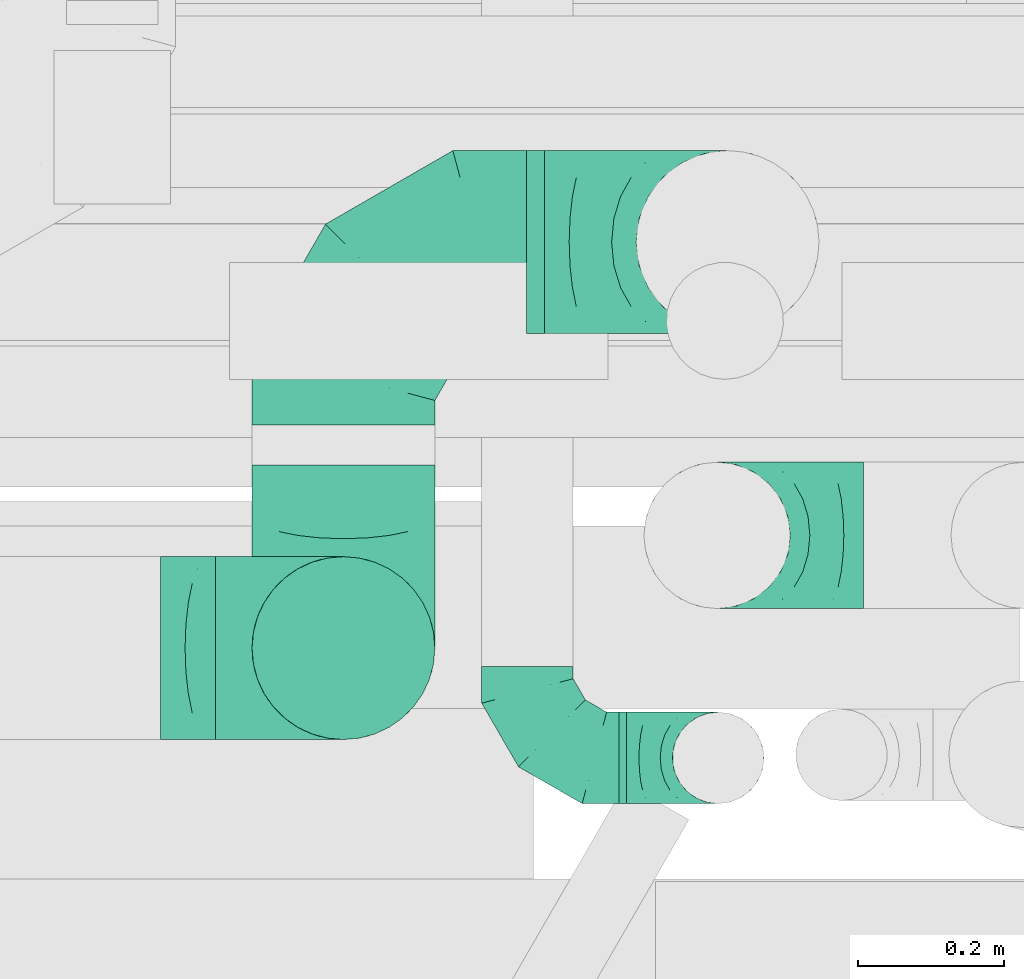
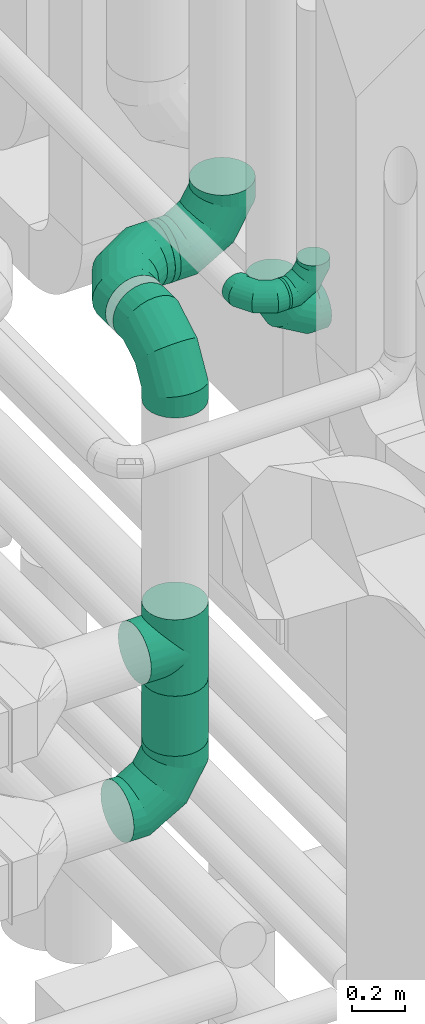
# One storey, part 299 of 337: 8 flow fittings, 3 flow segments.
"""IFC2X3 building model written with IfcOpenShell, lengths in millimetres."""

from ifc_helpers import new_model, entity, si_unit, converted_unit, derived_unit, direction, frame, origin, origin_2d_with_axis, place, context, subcontext, project, spatial, circle, extrude, faceted_brep, source, transform, mapped, material, type_object, type_shapes, element, save


model = new_model("IFC2X3")

# Units and contexts
model_context = context("Model", 3, precision=0.01, world=origin(), true_north=direction((6.12303176911189e-17, 1.0)))
body_context = subcontext(model_context, "Body", "Model", "MODEL_VIEW")
ifc_project = project(units=[si_unit("LENGTHUNIT", "METRE", prefix="MILLI"), si_unit("AREAUNIT", "SQUARE_METRE"), si_unit("VOLUMEUNIT", "CUBIC_METRE"), converted_unit("PLANEANGLEUNIT", "DEGREE", entity("IfcRatioMeasure", 0.0174532925199433), si_unit("PLANEANGLEUNIT", "RADIAN"), dimensions=[0, 0, 0, 0, 0, 0, 0]), si_unit("MASSUNIT", "GRAM", prefix="KILO"), derived_unit("MASSDENSITYUNIT", [(si_unit("MASSUNIT", "GRAM", prefix="KILO"), 1), (si_unit("LENGTHUNIT", "METRE"), -3)]), derived_unit("MOMENTOFINERTIAUNIT", [(si_unit("LENGTHUNIT", "METRE"), 4)]), si_unit("TIMEUNIT", "SECOND"), si_unit("FREQUENCYUNIT", "HERTZ"), si_unit("THERMODYNAMICTEMPERATUREUNIT", "DEGREE_CELSIUS"), derived_unit("THERMALTRANSMITTANCEUNIT", [(si_unit("MASSUNIT", "GRAM", prefix="KILO"), 1), (si_unit("THERMODYNAMICTEMPERATUREUNIT", "KELVIN"), -1), (si_unit("TIMEUNIT", "SECOND"), -3)]), derived_unit("VOLUMETRICFLOWRATEUNIT", [(si_unit("LENGTHUNIT", "METRE"), 3), (si_unit("TIMEUNIT", "SECOND"), -1)]), derived_unit("MASSFLOWRATEUNIT", [(si_unit("MASSUNIT", "GRAM", prefix="KILO"), 1), (si_unit("TIMEUNIT", "SECOND"), -1)]), derived_unit("ROTATIONALFREQUENCYUNIT", [(si_unit("TIMEUNIT", "SECOND"), -1)]), si_unit("ELECTRICCURRENTUNIT", "AMPERE"), si_unit("ELECTRICVOLTAGEUNIT", "VOLT"), si_unit("POWERUNIT", "WATT"), si_unit("FORCEUNIT", "NEWTON", prefix="KILO"), si_unit("ILLUMINANCEUNIT", "LUX"), si_unit("LUMINOUSFLUXUNIT", "LUMEN"), si_unit("LUMINOUSINTENSITYUNIT", "CANDELA"), derived_unit("USERDEFINED", [(si_unit("MASSUNIT", "GRAM", prefix="KILO"), -1), (si_unit("LENGTHUNIT", "METRE"), -2), (si_unit("TIMEUNIT", "SECOND"), 3), (si_unit("LUMINOUSFLUXUNIT", "LUMEN"), 1)]), derived_unit("LINEARVELOCITYUNIT", [(si_unit("LENGTHUNIT", "METRE"), 1), (si_unit("TIMEUNIT", "SECOND"), -1)]), si_unit("PRESSUREUNIT", "PASCAL"), derived_unit("USERDEFINED", [(si_unit("LENGTHUNIT", "METRE"), -2), (si_unit("MASSUNIT", "GRAM", prefix="KILO"), 1), (si_unit("TIMEUNIT", "SECOND"), -2)]), derived_unit("LINEARFORCEUNIT", [(si_unit("MASSUNIT", "GRAM", prefix="KILO"), 1), (si_unit("LENGTHUNIT", "METRE"), 1), (si_unit("TIMEUNIT", "SECOND"), -2), (si_unit("LENGTHUNIT", "METRE"), -1)]), derived_unit("PLANARFORCEUNIT", [(si_unit("MASSUNIT", "GRAM", prefix="KILO"), 1), (si_unit("LENGTHUNIT", "METRE"), 1), (si_unit("TIMEUNIT", "SECOND"), -2), (si_unit("LENGTHUNIT", "METRE"), -2)])], contexts=[model_context])

# Site, building, storey
site_placement = place(None, origin())
site = spatial("IfcSite", under=ifc_project, at=site_placement, CompositionType="ELEMENT")
building_placement = place(site_placement, origin())
building = spatial("IfcBuilding", under=site, at=building_placement, CompositionType="ELEMENT")
storey_placement = place(building_placement, origin())
storey = spatial("IfcBuildingStorey", under=building, at=storey_placement, CompositionType="ELEMENT", Elevation=0.0)

# Flow segments
duct_segment_type = type_object("IfcDuctSegmentType", PredefinedType="NOTDEFINED")
flow_segment_1_placement = place(storey_placement, frame((70743.1, 9622.1, 35423.4)))
element("IfcFlowSegment", 1, at=flow_segment_1_placement, inside=storey, type_object=duct_segment_type, context=body_context, shape_type="SweptSolid", body=[
    extrude(circle(Radius=125.0, at=origin_2d_with_axis()), frame((0.0, 126.6, 126.6), z_axis=(1.0, 0.0, 0.0), x_axis=(0.0, -1.0, 0.0)), (0.0, 0.0, 1.0), 24.9999999999164),
])
flow_segment_2_placement = place(storey_placement, frame((70869.58, 8979.52, 35675.9)))
element("IfcFlowSegment", 2, at=flow_segment_2_placement, inside=storey, type_object=duct_segment_type, context=body_context, shape_type="SweptSolid", body=[
    extrude(circle(Radius=62.5, at=origin_2d_with_axis()), frame((0.0, 64.1, 64.1), z_axis=(1.0, 0.0, 0.0), x_axis=(0.0, -1.0, 0.0)), (0.0, 0.0, 1.0), 10.6752096480788),
])
flow_segment_3_placement = place(storey_placement, frame((70366.5, 9067.1, 33750.0)))
element("IfcFlowSegment", 3, at=flow_segment_3_placement, inside=storey, type_object=duct_segment_type, context=body_context, shape_type="SweptSolid", body=[
    extrude(circle(Radius=125.0, at=origin_2d_with_axis()), frame((126.6, 126.6, 0.0), z_axis=(0.0, 0.0, 1.0), x_axis=(0.0, 1.0, 0.0)), (0.0, 0.0, 1.0), 275.000000000007),
])

# Flow fittings
ifc_material = material()
duct_fitting_type_1 = type_object("IfcDuctFittingType", PredefinedType="NOTDEFINED", material=ifc_material)
shared_shape_1 = source(origin(), body_context, "Body", "Brep", [
    faceted_brep([(-250.0, 0.0, -125.0), (-250.0, -32.35, -120.74), (-250.0, -62.5, -108.25), (-250.0, -88.39, -88.39), (-250.0, -108.25, -62.5), (-250.0, -120.74, -32.35), (-250.0, -125.0, 0.0), (-250.0, -120.74, 32.35), (-250.0, -108.25, 62.5), (-250.0, -88.39, 88.39), (-250.0, -62.5, 108.25), (-250.0, -32.35, 120.74), (-250.0, 0.0, 125.0), (-250.0, 32.35, 120.74), (-250.0, 62.5, 108.25), (-250.0, 88.39, 88.39), (-250.0, 108.25, 62.5), (-250.0, 120.74, 32.35), (-250.0, 125.0, 0.0), (-250.0, 120.74, -32.35), (-250.0, 108.25, -62.5), (-250.0, 88.39, -88.39), (-250.0, 62.5, -108.25), (-250.0, 32.35, -120.74), (-191.68, 32.35, 120.74), (-199.76, 62.5, 108.25), (-183.01, 0.0, 125.0), (-206.7, 88.39, 88.39), (-215.37, 120.74, 32.35), (-216.51, 125.0, 0.0), (-212.02, 108.25, 62.5), (-212.02, 108.25, -62.5), (-206.7, 88.39, -88.39), (-215.37, 120.74, -32.35), (-191.68, 32.35, -120.74), (-183.01, 0.0, -125.0), (-199.76, 62.5, -108.25), (-174.34, -32.35, -120.74), (-166.27, -62.5, -108.25), (-159.33, -88.39, -88.39), (-154.01, -108.25, -62.5), (-150.66, -120.74, -32.35), (-149.52, -125.0, 0.0), (-150.66, -120.74, 32.35), (-154.01, -108.25, 62.5), (-159.33, -88.39, 88.39), (-166.27, -62.5, 108.25), (-174.34, -32.35, 120.74), (-90.67, 90.67, 120.74), (-112.74, 112.74, 108.25), (-66.99, 66.99, 125.0), (-131.69, 131.69, 88.39), (-146.23, 146.23, 62.5), (-155.38, 155.38, 32.35), (-158.49, 158.49, 0.0), (-155.38, 155.38, -32.35), (-146.23, 146.23, -62.5), (-131.69, 131.69, -88.39), (-90.67, 90.67, -120.74), (-66.99, 66.99, -125.0), (-112.74, 112.74, -108.25), (-43.3, 43.3, -120.74), (-21.23, 21.23, -108.25), (-2.28, 2.28, -88.39), (12.26, -12.26, -62.5), (21.4, -21.4, -32.35), (24.52, -24.52, 0.0), (21.4, -21.4, 32.35), (12.26, -12.26, 62.5), (-2.28, 2.28, 88.39), (-21.23, 21.23, 108.25), (-43.3, 43.3, 120.74), (-32.35, 191.68, 120.74), (-62.5, 199.76, 108.25), (0.0, 183.01, 125.0), (-88.39, 206.7, 88.39), (-108.25, 212.02, 62.5), (-120.74, 215.37, 32.35), (-125.0, 216.51, 0.0), (-120.74, 215.37, -32.35), (-108.25, 212.02, -62.5), (-88.39, 206.7, -88.39), (-32.35, 191.68, -120.74), (0.0, 183.01, -125.0), (-62.5, 199.76, -108.25), (32.35, 174.34, -120.74), (62.5, 166.27, -108.25), (88.39, 159.33, -88.39), (108.25, 154.01, -62.5), (120.74, 150.66, -32.35), (125.0, 149.52, 0.0), (120.74, 150.66, 32.35), (108.25, 154.01, 62.5), (88.39, 159.33, 88.39), (62.5, 166.27, 108.25), (32.35, 174.34, 120.74), (-32.35, 250.0, -120.74), (-62.5, 250.0, -108.25), (-88.39, 250.0, -88.39), (-108.25, 250.0, -62.5), (-120.74, 250.0, -32.35), (-125.0, 250.0, 0.0), (-120.74, 250.0, 32.35), (-108.25, 250.0, 62.5), (-88.39, 250.0, 88.39), (-62.5, 250.0, 108.25), (-32.35, 250.0, 120.74), (0.0, 250.0, 125.0), (32.35, 250.0, 120.74), (62.5, 250.0, 108.25), (88.39, 250.0, 88.39), (108.25, 250.0, 62.5), (120.74, 250.0, 32.35), (125.0, 250.0, 0.0), (120.74, 250.0, -32.35), (108.25, 250.0, -62.5), (88.39, 250.0, -88.39), (62.5, 250.0, -108.25), (32.35, 250.0, -120.74), (0.0, 250.0, -125.0)], [[[0, 1, 2, 3, 4, 5, 6, 7, 8, 9, 10, 11, 12, 13, 14, 15, 16, 17, 18, 19, 20, 21, 22, 23]], [[24, 25, 14, 13]], [[26, 24, 13, 12]], [[14, 25, 27, 15]], [[28, 29, 18, 17]], [[30, 28, 17, 16]], [[15, 27, 30, 16]], [[20, 31, 32, 21]], [[33, 31, 20, 19]], [[18, 29, 33, 19]], [[34, 35, 0, 23]], [[36, 34, 23, 22]], [[21, 32, 36, 22]], [[1, 0, 35, 37]], [[2, 1, 37, 38]], [[38, 39, 3, 2]], [[5, 4, 40, 41]], [[6, 5, 41, 42]], [[39, 40, 4, 3]], [[6, 42, 43, 7]], [[7, 43, 44, 8]], [[8, 44, 45, 9]], [[9, 45, 46, 10]], [[10, 46, 47, 11]], [[26, 12, 11, 47]], [[48, 49, 25, 24]], [[50, 48, 24, 26]], [[27, 25, 49, 51]], [[52, 53, 28, 30]], [[51, 52, 30, 27]], [[29, 28, 53, 54]], [[55, 56, 31, 33]], [[54, 55, 33, 29]], [[32, 31, 56, 57]], [[58, 59, 35, 34]], [[60, 58, 34, 36]], [[57, 60, 36, 32]], [[37, 35, 59, 61]], [[38, 37, 61, 62]], [[39, 38, 62, 63]], [[41, 40, 64, 65]], [[42, 41, 65, 66]], [[63, 64, 40, 39]], [[43, 42, 66, 67]], [[44, 43, 67, 68]], [[68, 69, 45, 44]], [[46, 45, 69, 70]], [[47, 46, 70, 71]], [[26, 47, 71, 50]], [[72, 73, 49, 48]], [[74, 72, 48, 50]], [[51, 49, 73, 75]], [[76, 77, 53, 52]], [[75, 76, 52, 51]], [[54, 53, 77, 78]], [[79, 80, 56, 55]], [[78, 79, 55, 54]], [[57, 56, 80, 81]], [[82, 83, 59, 58]], [[84, 82, 58, 60]], [[81, 84, 60, 57]], [[61, 59, 83, 85]], [[62, 61, 85, 86]], [[63, 62, 86, 87]], [[65, 64, 88, 89]], [[66, 65, 89, 90]], [[87, 88, 64, 63]], [[67, 66, 90, 91]], [[68, 67, 91, 92]], [[92, 93, 69, 68]], [[70, 69, 93, 94]], [[71, 70, 94, 95]], [[50, 71, 95, 74]], [[96, 97, 98, 99, 100, 101, 102, 103, 104, 105, 106, 107, 108, 109, 110, 111, 112, 113, 114, 115, 116, 117, 118, 119]], [[72, 74, 107, 106]], [[73, 72, 106, 105]], [[75, 73, 105, 104]], [[77, 76, 103, 102]], [[78, 77, 102, 101]], [[75, 104, 103, 76]], [[78, 101, 100, 79]], [[79, 100, 99, 80]], [[80, 99, 98, 81]], [[84, 97, 96, 82]], [[82, 96, 119, 83]], [[84, 81, 98, 97]], [[83, 119, 118, 85]], [[85, 118, 117, 86]], [[116, 87, 86, 117]], [[88, 115, 114, 89]], [[89, 114, 113, 90]], [[115, 88, 87, 116]], [[91, 90, 113, 112]], [[92, 91, 112, 111]], [[111, 110, 93, 92]], [[95, 94, 109, 108]], [[74, 95, 108, 107]], [[110, 109, 94, 93]]]),
])
type_shapes(duct_fitting_type_1, [shared_shape_1])
for number, where, z_axis, x_axis in (
    (4, (70493.1, 9193.7, 35550.0), (-1.0, 0.0, 0.0), (0.0, 0.0, 1.0)),
    (5, (70493.1, 9748.7, 35550.0), (0.0, 0.0, 1.0), (-1.0, 0.0, 0.0)),
    (6, (71018.1, 9748.7, 35550.0), (0.0, -1.0, 0.0), (1.0, 0.0, 0.0)),
    (7, (70493.1, 9193.7, 33500.0), (0.0, -1.0, 0.0), (1.0, 0.0, 0.0)),
):
    element("IfcFlowFitting", number, at=place(storey_placement, frame(where, z_axis=z_axis, x_axis=x_axis)), inside=storey, type_object=duct_fitting_type_1, material=ifc_material, context=body_context, shape_type="MappedRepresentation", body=[
        mapped(shared_shape_1, transform((0.0, 0.0, 0.0), scale=1.0)),
    ])
duct_fitting_type_2 = type_object("IfcDuctFittingType", PredefinedType="NOTDEFINED", material=ifc_material)
shared_shape_2 = source(origin(), body_context, "Body", "Brep", [
    faceted_brep([(-200.0, 0.0, -100.0), (-200.0, -25.88, -96.59), (-200.0, -50.0, -86.6), (-200.0, -70.71, -70.71), (-200.0, -86.6, -50.0), (-200.0, -96.59, -25.88), (-200.0, -100.0, 0.0), (-200.0, -96.59, 25.88), (-200.0, -86.6, 50.0), (-200.0, -70.71, 70.71), (-200.0, -50.0, 86.6), (-200.0, -25.88, 96.59), (-200.0, 0.0, 100.0), (-200.0, 25.88, 96.59), (-200.0, 50.0, 86.6), (-200.0, 70.71, 70.71), (-200.0, 86.6, 50.0), (-200.0, 96.59, 25.88), (-200.0, 100.0, 0.0), (-200.0, 96.59, -25.88), (-200.0, 86.6, -50.0), (-200.0, 70.71, -70.71), (-200.0, 50.0, -86.6), (-200.0, 25.88, -96.59), (-153.35, 25.88, 96.59), (-159.81, 50.0, 86.6), (-146.41, 0.0, 100.0), (-165.36, 70.71, 70.71), (-172.29, 96.59, 25.88), (-173.21, 100.0, 0.0), (-169.62, 86.6, 50.0), (-169.62, 86.6, -50.0), (-165.36, 70.71, -70.71), (-172.29, 96.59, -25.88), (-153.35, 25.88, -96.59), (-146.41, 0.0, -100.0), (-159.81, 50.0, -86.6), (-139.48, -25.88, -96.59), (-133.01, -50.0, -86.6), (-127.46, -70.71, -70.71), (-123.21, -86.6, -50.0), (-120.53, -96.59, -25.88), (-119.62, -100.0, 0.0), (-120.53, -96.59, 25.88), (-123.21, -86.6, 50.0), (-127.46, -70.71, 70.71), (-133.01, -50.0, 86.6), (-139.48, -25.88, 96.59), (-72.54, 72.54, 96.59), (-90.19, 90.19, 86.6), (-53.59, 53.59, 100.0), (-105.35, 105.35, 70.71), (-116.99, 116.99, 50.0), (-124.3, 124.3, 25.88), (-126.79, 126.79, 0.0), (-124.3, 124.3, -25.88), (-116.99, 116.99, -50.0), (-105.35, 105.35, -70.71), (-72.54, 72.54, -96.59), (-53.59, 53.59, -100.0), (-90.19, 90.19, -86.6), (-34.64, 34.64, -96.59), (-16.99, 16.99, -86.6), (-1.83, 1.83, -70.71), (9.81, -9.81, -50.0), (17.12, -17.12, -25.88), (19.62, -19.62, 0.0), (17.12, -17.12, 25.88), (9.81, -9.81, 50.0), (-1.83, 1.83, 70.71), (-16.99, 16.99, 86.6), (-34.64, 34.64, 96.59), (-25.88, 153.35, 96.59), (-50.0, 159.81, 86.6), (0.0, 146.41, 100.0), (-70.71, 165.36, 70.71), (-86.6, 169.62, 50.0), (-96.59, 172.29, 25.88), (-100.0, 173.21, 0.0), (-96.59, 172.29, -25.88), (-86.6, 169.62, -50.0), (-70.71, 165.36, -70.71), (-25.88, 153.35, -96.59), (0.0, 146.41, -100.0), (-50.0, 159.81, -86.6), (25.88, 139.48, -96.59), (50.0, 133.01, -86.6), (70.71, 127.46, -70.71), (86.6, 123.21, -50.0), (96.59, 120.53, -25.88), (100.0, 119.62, 0.0), (96.59, 120.53, 25.88), (86.6, 123.21, 50.0), (70.71, 127.46, 70.71), (50.0, 133.01, 86.6), (25.88, 139.48, 96.59), (-25.88, 200.0, -96.59), (-50.0, 200.0, -86.6), (-70.71, 200.0, -70.71), (-86.6, 200.0, -50.0), (-96.59, 200.0, -25.88), (-100.0, 200.0, 0.0), (-96.59, 200.0, 25.88), (-86.6, 200.0, 50.0), (-70.71, 200.0, 70.71), (-50.0, 200.0, 86.6), (-25.88, 200.0, 96.59), (0.0, 200.0, 100.0), (25.88, 200.0, 96.59), (50.0, 200.0, 86.6), (70.71, 200.0, 70.71), (86.6, 200.0, 50.0), (96.59, 200.0, 25.88), (100.0, 200.0, 0.0), (96.59, 200.0, -25.88), (86.6, 200.0, -50.0), (70.71, 200.0, -70.71), (50.0, 200.0, -86.6), (25.88, 200.0, -96.59), (0.0, 200.0, -100.0)], [[[0, 1, 2, 3, 4, 5, 6, 7, 8, 9, 10, 11, 12, 13, 14, 15, 16, 17, 18, 19, 20, 21, 22, 23]], [[24, 25, 14, 13]], [[26, 24, 13, 12]], [[14, 25, 27, 15]], [[28, 29, 18, 17]], [[30, 28, 17, 16]], [[15, 27, 30, 16]], [[20, 31, 32, 21]], [[33, 31, 20, 19]], [[18, 29, 33, 19]], [[34, 35, 0, 23]], [[36, 34, 23, 22]], [[32, 36, 22, 21]], [[1, 0, 35, 37]], [[2, 1, 37, 38]], [[38, 39, 3, 2]], [[5, 4, 40, 41]], [[6, 5, 41, 42]], [[39, 40, 4, 3]], [[6, 42, 43, 7]], [[7, 43, 44, 8]], [[8, 44, 45, 9]], [[9, 45, 46, 10]], [[10, 46, 47, 11]], [[26, 12, 11, 47]], [[48, 49, 25, 24]], [[50, 48, 24, 26]], [[27, 25, 49, 51]], [[52, 53, 28, 30]], [[51, 52, 30, 27]], [[29, 28, 53, 54]], [[55, 56, 31, 33]], [[54, 55, 33, 29]], [[32, 31, 56, 57]], [[58, 59, 35, 34]], [[60, 58, 34, 36]], [[57, 60, 36, 32]], [[37, 35, 59, 61]], [[38, 37, 61, 62]], [[39, 38, 62, 63]], [[41, 40, 64, 65]], [[42, 41, 65, 66]], [[63, 64, 40, 39]], [[43, 42, 66, 67]], [[44, 43, 67, 68]], [[68, 69, 45, 44]], [[46, 45, 69, 70]], [[47, 46, 70, 71]], [[26, 47, 71, 50]], [[72, 73, 49, 48]], [[74, 72, 48, 50]], [[51, 49, 73, 75]], [[76, 77, 53, 52]], [[75, 76, 52, 51]], [[54, 53, 77, 78]], [[79, 80, 56, 55]], [[78, 79, 55, 54]], [[57, 56, 80, 81]], [[82, 83, 59, 58]], [[84, 82, 58, 60]], [[81, 84, 60, 57]], [[61, 59, 83, 85]], [[62, 61, 85, 86]], [[63, 62, 86, 87]], [[65, 64, 88, 89]], [[66, 65, 89, 90]], [[87, 88, 64, 63]], [[67, 66, 90, 91]], [[68, 67, 91, 92]], [[92, 93, 69, 68]], [[70, 69, 93, 94]], [[71, 70, 94, 95]], [[50, 71, 95, 74]], [[96, 97, 98, 99, 100, 101, 102, 103, 104, 105, 106, 107, 108, 109, 110, 111, 112, 113, 114, 115, 116, 117, 118, 119]], [[72, 74, 107, 106]], [[73, 72, 106, 105]], [[75, 73, 105, 104]], [[102, 101, 78, 77]], [[103, 102, 77, 76]], [[75, 104, 103, 76]], [[78, 101, 100, 79]], [[79, 100, 99, 80]], [[80, 99, 98, 81]], [[84, 97, 96, 82]], [[82, 96, 119, 83]], [[84, 81, 98, 97]], [[118, 117, 86, 85]], [[119, 118, 85, 83]], [[116, 87, 86, 117]], [[88, 115, 114, 89]], [[89, 114, 113, 90]], [[115, 88, 87, 116]], [[91, 90, 113, 112]], [[92, 91, 112, 111]], [[111, 110, 93, 92]], [[95, 94, 109, 108]], [[74, 95, 108, 107]], [[110, 109, 94, 93]]]),
])
type_shapes(duct_fitting_type_2, [shared_shape_2])
flow_fitting_1_placement = place(storey_placement, frame((71003.8, 9347.75, 35400.0), z_axis=(0.0, 1.0, 0.0), x_axis=(-1.0, 0.0, 0.0)))
element("IfcFlowFitting", 8, at=flow_fitting_1_placement, inside=storey, type_object=duct_fitting_type_2, material=ifc_material, context=body_context, shape_type="MappedRepresentation", body=[
    mapped(shared_shape_2, transform((0.0, 0.0, 0.0), scale=1.0)),
])
duct_fitting_type_3 = type_object("IfcDuctFittingType", PredefinedType="NOTDEFINED", material=ifc_material)
shared_shape_3 = source(origin(), body_context, "Body", "Brep", [
    faceted_brep([(-125.0, 0.0, -62.5), (-125.0, -16.18, -60.37), (-125.0, -31.25, -54.13), (-125.0, -44.19, -44.19), (-125.0, -54.13, -31.25), (-125.0, -60.37, -16.18), (-125.0, -62.5, 0.0), (-125.0, -60.37, 16.18), (-125.0, -54.13, 31.25), (-125.0, -44.19, 44.19), (-125.0, -31.25, 54.13), (-125.0, -16.18, 60.37), (-125.0, 0.0, 62.5), (-125.0, 16.18, 60.37), (-125.0, 31.25, 54.13), (-125.0, 44.19, 44.19), (-125.0, 54.13, 31.25), (-125.0, 60.37, 16.18), (-125.0, 62.5, 0.0), (-125.0, 60.37, -16.18), (-125.0, 54.13, -31.25), (-125.0, 44.19, -44.19), (-125.0, 31.25, -54.13), (-125.0, 16.18, -60.37), (-95.84, 16.18, 60.37), (-99.88, 31.25, 54.13), (-91.51, 0.0, 62.5), (-103.35, 44.19, 44.19), (-107.68, 60.37, 16.18), (-108.25, 62.5, 0.0), (-106.01, 54.13, 31.25), (-106.01, 54.13, -31.25), (-103.35, 44.19, -44.19), (-107.68, 60.37, -16.18), (-95.84, 16.18, -60.37), (-91.51, 0.0, -62.5), (-99.88, 31.25, -54.13), (-87.17, -16.18, -60.37), (-83.13, -31.25, -54.13), (-79.66, -44.19, -44.19), (-77.0, -54.13, -31.25), (-75.33, -60.37, -16.18), (-74.76, -62.5, 0.0), (-75.33, -60.37, 16.18), (-77.0, -54.13, 31.25), (-79.66, -44.19, 44.19), (-83.13, -31.25, 54.13), (-87.17, -16.18, 60.37), (-45.34, 45.34, 60.37), (-56.37, 56.37, 54.13), (-33.49, 33.49, 62.5), (-65.85, 65.85, 44.19), (-73.12, 73.12, 31.25), (-77.69, 77.69, 16.18), (-79.25, 79.25, 0.0), (-77.69, 77.69, -16.18), (-73.12, 73.12, -31.25), (-65.85, 65.85, -44.19), (-45.34, 45.34, -60.37), (-33.49, 33.49, -62.5), (-56.37, 56.37, -54.13), (-21.65, 21.65, -60.37), (-10.62, 10.62, -54.13), (-1.14, 1.14, -44.19), (6.13, -6.13, -31.25), (10.7, -10.7, -16.18), (12.26, -12.26, 0.0), (10.7, -10.7, 16.18), (6.13, -6.13, 31.25), (-1.14, 1.14, 44.19), (-10.62, 10.62, 54.13), (-21.65, 21.65, 60.37), (-16.18, 95.84, 60.37), (-31.25, 99.88, 54.13), (0.0, 91.51, 62.5), (-44.19, 103.35, 44.19), (-54.13, 106.01, 31.25), (-60.37, 107.68, 16.18), (-62.5, 108.25, 0.0), (-60.37, 107.68, -16.18), (-54.13, 106.01, -31.25), (-44.19, 103.35, -44.19), (-16.18, 95.84, -60.37), (0.0, 91.51, -62.5), (-31.25, 99.88, -54.13), (16.18, 87.17, -60.37), (31.25, 83.13, -54.13), (44.19, 79.66, -44.19), (54.13, 77.0, -31.25), (60.37, 75.33, -16.18), (62.5, 74.76, 0.0), (60.37, 75.33, 16.18), (54.13, 77.0, 31.25), (44.19, 79.66, 44.19), (31.25, 83.13, 54.13), (16.18, 87.17, 60.37), (-16.18, 125.0, -60.37), (-31.25, 125.0, -54.13), (-44.19, 125.0, -44.19), (-54.13, 125.0, -31.25), (-60.37, 125.0, -16.18), (-62.5, 125.0, 0.0), (-60.37, 125.0, 16.18), (-54.13, 125.0, 31.25), (-44.19, 125.0, 44.19), (-31.25, 125.0, 54.13), (-16.18, 125.0, 60.37), (0.0, 125.0, 62.5), (16.18, 125.0, 60.37), (31.25, 125.0, 54.13), (44.19, 125.0, 44.19), (54.13, 125.0, 31.25), (60.37, 125.0, 16.18), (62.5, 125.0, 0.0), (60.37, 125.0, -16.18), (54.13, 125.0, -31.25), (44.19, 125.0, -44.19), (31.25, 125.0, -54.13), (16.18, 125.0, -60.37), (0.0, 125.0, -62.5)], [[[0, 1, 2, 3, 4, 5, 6, 7, 8, 9, 10, 11, 12, 13, 14, 15, 16, 17, 18, 19, 20, 21, 22, 23]], [[24, 25, 14, 13]], [[26, 24, 13, 12]], [[14, 25, 27, 15]], [[28, 29, 18, 17]], [[30, 28, 17, 16]], [[15, 27, 30, 16]], [[20, 31, 32, 21]], [[33, 31, 20, 19]], [[18, 29, 33, 19]], [[34, 35, 0, 23]], [[36, 34, 23, 22]], [[21, 32, 36, 22]], [[1, 0, 35, 37]], [[2, 1, 37, 38]], [[38, 39, 3, 2]], [[5, 4, 40, 41]], [[6, 5, 41, 42]], [[39, 40, 4, 3]], [[6, 42, 43, 7]], [[7, 43, 44, 8]], [[45, 9, 8, 44]], [[9, 45, 46, 10]], [[10, 46, 47, 11]], [[26, 12, 11, 47]], [[48, 49, 25, 24]], [[50, 48, 24, 26]], [[27, 25, 49, 51]], [[52, 53, 28, 30]], [[51, 52, 30, 27]], [[29, 28, 53, 54]], [[55, 56, 31, 33]], [[54, 55, 33, 29]], [[57, 32, 31, 56]], [[58, 59, 35, 34]], [[60, 58, 34, 36]], [[57, 60, 36, 32]], [[37, 35, 59, 61]], [[38, 37, 61, 62]], [[39, 38, 62, 63]], [[41, 40, 64, 65]], [[42, 41, 65, 66]], [[63, 64, 40, 39]], [[43, 42, 66, 67]], [[44, 43, 67, 68]], [[68, 69, 45, 44]], [[46, 45, 69, 70]], [[47, 46, 70, 71]], [[26, 47, 71, 50]], [[72, 73, 49, 48]], [[74, 72, 48, 50]], [[51, 49, 73, 75]], [[76, 77, 53, 52]], [[75, 76, 52, 51]], [[54, 53, 77, 78]], [[79, 80, 56, 55]], [[78, 79, 55, 54]], [[81, 57, 56, 80]], [[82, 83, 59, 58]], [[84, 82, 58, 60]], [[81, 84, 60, 57]], [[61, 59, 83, 85]], [[62, 61, 85, 86]], [[63, 62, 86, 87]], [[65, 64, 88, 89]], [[66, 65, 89, 90]], [[87, 88, 64, 63]], [[67, 66, 90, 91]], [[68, 67, 91, 92]], [[92, 93, 69, 68]], [[70, 69, 93, 94]], [[71, 70, 94, 95]], [[50, 71, 95, 74]], [[96, 97, 98, 99, 100, 101, 102, 103, 104, 105, 106, 107, 108, 109, 110, 111, 112, 113, 114, 115, 116, 117, 118, 119]], [[72, 74, 107, 106]], [[73, 72, 106, 105]], [[75, 73, 105, 104]], [[77, 76, 103, 102]], [[78, 77, 102, 101]], [[75, 104, 103, 76]], [[78, 101, 100, 79]], [[79, 100, 99, 80]], [[80, 99, 98, 81]], [[96, 119, 83, 82]], [[97, 96, 82, 84]], [[84, 81, 98, 97]], [[83, 119, 118, 85]], [[85, 118, 117, 86]], [[116, 87, 86, 117]], [[88, 115, 114, 89]], [[89, 114, 113, 90]], [[115, 88, 87, 116]], [[91, 90, 113, 112]], [[92, 91, 112, 111]], [[111, 110, 93, 92]], [[95, 94, 109, 108]], [[74, 95, 108, 107]], [[110, 109, 94, 93]]]),
])
type_shapes(duct_fitting_type_3, [shared_shape_3])
for number, where, z_axis, x_axis in (
    (9, (70744.58, 9043.62, 35740.0), (0.0, 0.0, 1.0), (0.0, -1.0, 0.0)),
    (10, (71005.26, 9043.62, 35740.0), (0.0, -1.0, 0.0), (1.0, 0.0, 0.0)),
):
    element("IfcFlowFitting", number, at=place(storey_placement, frame(where, z_axis=z_axis, x_axis=x_axis)), inside=storey, type_object=duct_fitting_type_3, material=ifc_material, context=body_context, shape_type="MappedRepresentation", body=[
        mapped(shared_shape_3, transform((0.0, 0.0, 0.0), scale=1.0)),
    ])
duct_fitting_type_4 = type_object("IfcDuctFittingType", PredefinedType="NOTDEFINED", material=ifc_material)
shared_shape_4 = source(origin(), body_context, "Body", "Brep", [
    faceted_brep([(22.44, -22.44, -122.97), (175.0, 0.0, -125.0), (175.0, -32.35, -120.74), (175.0, -62.5, -108.25), (75.83, -75.83, -99.37), (65.72, -65.72, -106.33), (175.0, -88.39, -88.39), (55.24, -55.24, -112.13), (11.24, -11.24, -124.49), (0.0, 0.0, -125.0), (-11.24, -11.24, -124.49), (-175.0, 0.0, -125.0), (44.49, -44.49, -116.81), (33.54, -33.54, -120.42), (175.0, -108.25, -62.5), (102.86, -102.86, -71.03), (175.0, -120.74, -32.35), (116.36, -116.36, -45.66), (175.0, -114.5, -47.43), (123.99, -123.99, -15.84), (175.0, -125.0, 0.0), (125.0, -125.0, 0.0), (-123.99, -123.99, -15.84), (-125.0, -125.0, 0.0), (-175.0, -125.0, 0.0), (175.0, -122.87, -16.18), (110.21, -110.21, -58.98), (121.05, -121.05, -31.19), (94.55, -94.55, -81.76), (85.49, -85.49, -91.2), (123.99, -123.99, 15.84), (-123.99, -123.99, 15.84), (175.0, -114.5, 47.43), (175.0, -108.25, 62.5), (110.21, -110.21, 58.98), (175.0, -120.74, 32.35), (121.05, -121.05, 31.19), (175.0, -122.87, 16.18), (102.86, -102.86, 71.03), (175.0, -88.39, 88.39), (116.36, -116.36, 45.66), (94.55, -94.55, 81.76), (85.49, -85.49, 91.2), (75.83, -75.83, 99.37), (65.72, -65.72, 106.33), (175.0, -62.5, 108.25), (55.24, -55.24, 112.13), (175.0, -32.35, 120.74), (22.44, -22.44, 122.97), (175.0, 0.0, 125.0), (44.49, -44.49, 116.81), (33.54, -33.54, 120.42), (11.24, -11.24, 124.49), (0.0, 0.0, 125.0), (-11.24, -11.24, 124.49), (-175.0, 0.0, 125.0), (32.35, -175.0, -120.74), (62.5, -175.0, -108.25), (88.39, -175.0, -88.39), (108.25, -175.0, -62.5), (114.5, -175.0, -47.43), (120.74, -175.0, -32.35), (122.87, -175.0, -16.18), (125.0, -175.0, 0.0), (122.87, -175.0, 16.18), (120.74, -175.0, 32.35), (114.5, -175.0, 47.43), (108.25, -175.0, 62.5), (88.39, -175.0, 88.39), (62.5, -175.0, 108.25), (32.35, -175.0, 120.74), (0.0, -175.0, 125.0), (-32.35, -175.0, 120.74), (-62.5, -175.0, 108.25), (-88.39, -175.0, 88.39), (-108.25, -175.0, 62.5), (-114.5, -175.0, 47.43), (-120.74, -175.0, 32.35), (-122.87, -175.0, 16.18), (-125.0, -175.0, 0.0), (-122.87, -175.0, -16.18), (-120.74, -175.0, -32.35), (-114.5, -175.0, -47.43), (-108.25, -175.0, -62.5), (-88.39, -175.0, -88.39), (-62.5, -175.0, -108.25), (-32.35, -175.0, -120.74), (0.0, -175.0, -125.0), (-22.44, -22.44, -122.97), (-75.83, -75.83, -99.37), (-65.72, -65.72, -106.33), (-55.24, -55.24, -112.13), (-44.49, -44.49, -116.81), (-33.54, -33.54, -120.42), (-102.86, -102.86, -71.03), (-116.36, -116.36, -45.66), (-110.21, -110.21, -58.98), (-121.05, -121.05, -31.19), (-94.55, -94.55, -81.76), (-85.49, -85.49, -91.2), (-110.21, -110.21, 58.98), (-121.05, -121.05, 31.19), (-102.86, -102.86, 71.03), (-116.36, -116.36, 45.66), (-94.55, -94.55, 81.76), (-85.49, -85.49, 91.2), (-75.83, -75.83, 99.37), (-65.72, -65.72, 106.33), (-55.24, -55.24, 112.13), (-22.44, -22.44, 122.97), (-44.49, -44.49, 116.81), (-33.54, -33.54, 120.42), (-175.0, -32.35, -120.74), (-175.0, -62.5, -108.25), (-175.0, -88.39, -88.39), (-175.0, -108.25, -62.5), (-175.0, -114.5, -47.43), (-175.0, -120.74, -32.35), (-175.0, -122.87, -16.18), (-175.0, -122.87, 16.18), (-175.0, -120.74, 32.35), (-175.0, -114.5, 47.43), (-175.0, -108.25, 62.5), (-175.0, -88.39, 88.39), (-175.0, -62.5, 108.25), (-175.0, -32.35, 120.74), (-175.0, 32.35, 120.74), (-175.0, 62.5, 108.25), (-175.0, 88.39, 88.39), (-175.0, 108.25, 62.5), (-175.0, 120.74, 32.35), (-175.0, 125.0, 0.0), (-175.0, 120.74, -32.35), (-175.0, 108.25, -62.5), (-175.0, 88.39, -88.39), (-175.0, 62.5, -108.25), (-175.0, 32.35, -120.74), (175.0, 32.35, -120.74), (175.0, 62.5, -108.25), (175.0, 88.39, -88.39), (175.0, 108.25, -62.5), (175.0, 120.74, -32.35), (175.0, 125.0, 0.0), (175.0, 120.74, 32.35), (175.0, 108.25, 62.5), (175.0, 88.39, 88.39), (175.0, 62.5, 108.25), (175.0, 32.35, 120.74)], [[[0, 1, 2]], [[3, 4, 5]], [[4, 3, 6]], [[2, 3, 7]], [[5, 7, 3]], [[8, 9, 1]], [[9, 10, 11]], [[0, 8, 1]], [[12, 13, 2]], [[7, 12, 2]], [[0, 2, 13]], [[14, 15, 6]], [[16, 17, 18]], [[19, 20, 21]], [[22, 23, 24]], [[20, 19, 25]], [[26, 18, 17]], [[27, 16, 25]], [[28, 29, 6]], [[15, 28, 6]], [[27, 25, 19]], [[26, 14, 18]], [[27, 17, 16]], [[15, 14, 26]], [[6, 29, 4]], [[30, 21, 20]], [[23, 31, 24]], [[32, 33, 34]], [[35, 36, 37]], [[38, 33, 39]], [[40, 35, 32]], [[30, 37, 36]], [[40, 36, 35]], [[38, 34, 33]], [[41, 38, 39]], [[32, 34, 40]], [[30, 20, 37]], [[39, 42, 41]], [[42, 39, 43]], [[44, 43, 45]], [[46, 45, 47]], [[45, 46, 44]], [[39, 45, 43]], [[48, 47, 49]], [[50, 46, 47]], [[51, 50, 47]], [[52, 48, 49]], [[53, 52, 49]], [[54, 53, 55]], [[51, 47, 48]], [[56, 57, 58, 59, 60, 61, 62, 63, 64, 65, 66, 67, 68, 69, 70, 71, 72, 73, 74, 75, 76, 77, 78, 79, 80, 81, 82, 83, 84, 85, 86, 87]], [[48, 71, 70]], [[69, 43, 44]], [[43, 69, 68]], [[70, 69, 46]], [[44, 46, 69]], [[52, 53, 71]], [[48, 52, 71]], [[50, 51, 70]], [[46, 50, 70]], [[48, 70, 51]], [[67, 38, 68]], [[65, 40, 66]], [[30, 63, 21]], [[63, 30, 64]], [[34, 66, 40]], [[36, 65, 64]], [[41, 42, 68]], [[38, 41, 68]], [[36, 64, 30]], [[34, 67, 66]], [[36, 40, 65]], [[38, 67, 34]], [[68, 42, 43]], [[19, 21, 63]], [[60, 59, 26]], [[62, 61, 27]], [[15, 59, 58]], [[17, 61, 60]], [[19, 62, 27]], [[17, 27, 61]], [[15, 26, 59]], [[28, 15, 58]], [[60, 26, 17]], [[19, 63, 62]], [[58, 29, 28]], [[29, 58, 4]], [[5, 4, 57]], [[7, 57, 56]], [[57, 7, 5]], [[58, 57, 4]], [[0, 56, 87]], [[12, 7, 56]], [[13, 12, 56]], [[8, 0, 87]], [[9, 8, 87]], [[13, 56, 0]], [[88, 87, 86]], [[85, 89, 90]], [[89, 85, 84]], [[86, 85, 91]], [[90, 91, 85]], [[10, 9, 87]], [[88, 10, 87]], [[92, 93, 86]], [[91, 92, 86]], [[88, 86, 93]], [[83, 94, 84]], [[81, 95, 82]], [[22, 79, 23]], [[79, 22, 80]], [[96, 82, 95]], [[97, 81, 80]], [[98, 99, 84]], [[94, 98, 84]], [[97, 80, 22]], [[96, 83, 82]], [[97, 95, 81]], [[94, 83, 96]], [[84, 99, 89]], [[31, 23, 79]], [[76, 75, 100]], [[77, 101, 78]], [[102, 75, 74]], [[103, 77, 76]], [[31, 78, 101]], [[103, 101, 77]], [[102, 100, 75]], [[104, 102, 74]], [[76, 100, 103]], [[31, 79, 78]], [[74, 105, 104]], [[105, 74, 106]], [[107, 106, 73]], [[108, 73, 72]], [[73, 108, 107]], [[74, 73, 106]], [[109, 72, 71]], [[110, 108, 72]], [[111, 110, 72]], [[54, 109, 71]], [[53, 54, 71]], [[111, 72, 109]], [[11, 112, 113, 114, 115, 116, 117, 118, 24, 119, 120, 121, 122, 123, 124, 125, 55, 126, 127, 128, 129, 130, 131, 132, 133, 134, 135, 136]], [[137, 138, 139, 140, 141, 142, 143, 144, 145, 146, 147, 49, 47, 45, 39, 33, 32, 35, 37, 20, 25, 16, 18, 14, 6, 3, 2, 1]], [[53, 49, 147, 126, 55]], [[127, 126, 147, 146]], [[146, 145, 128, 127]], [[129, 128, 145, 144]], [[130, 129, 144, 143]], [[131, 130, 143, 142]], [[132, 131, 142, 141]], [[133, 132, 141, 140]], [[140, 139, 134, 133]], [[135, 134, 139, 138]], [[136, 135, 138, 137]], [[9, 11, 136, 137, 1]], [[93, 92, 112]], [[88, 93, 112]], [[10, 88, 11]], [[88, 112, 11]], [[112, 92, 91]], [[112, 91, 113]], [[113, 90, 89]], [[90, 113, 91]], [[113, 89, 114]], [[98, 94, 114]], [[99, 98, 114]], [[95, 117, 116]], [[95, 97, 117]], [[95, 116, 96]], [[94, 96, 115]], [[116, 115, 96]], [[115, 114, 94]], [[22, 24, 118]], [[118, 117, 97]], [[118, 97, 22]], [[99, 114, 89]], [[101, 103, 120]], [[102, 104, 123]], [[100, 102, 122]], [[101, 119, 31]], [[100, 122, 121]], [[100, 121, 103]], [[24, 31, 119]], [[120, 119, 101]], [[103, 121, 120]], [[102, 123, 122]], [[104, 105, 123]], [[110, 111, 125]], [[108, 110, 125]], [[109, 54, 55]], [[111, 109, 125]], [[106, 107, 124]], [[106, 124, 123]], [[108, 124, 107]], [[108, 125, 124]], [[109, 55, 125]], [[106, 123, 105]]]),
])
type_shapes(duct_fitting_type_4, [shared_shape_4])
flow_fitting_2_placement = place(storey_placement, frame((70493.1, 9193.7, 34200.0), z_axis=(0.0, 1.0, 0.0), x_axis=(0.0, 0.0, 1.0)))
element("IfcFlowFitting", 11, at=flow_fitting_2_placement, inside=storey, type_object=duct_fitting_type_4, material=ifc_material, context=body_context, shape_type="MappedRepresentation", body=[
    mapped(shared_shape_4, transform((0.0, 0.0, 0.0), scale=1.0)),
])

save(model, "model.ifc")
